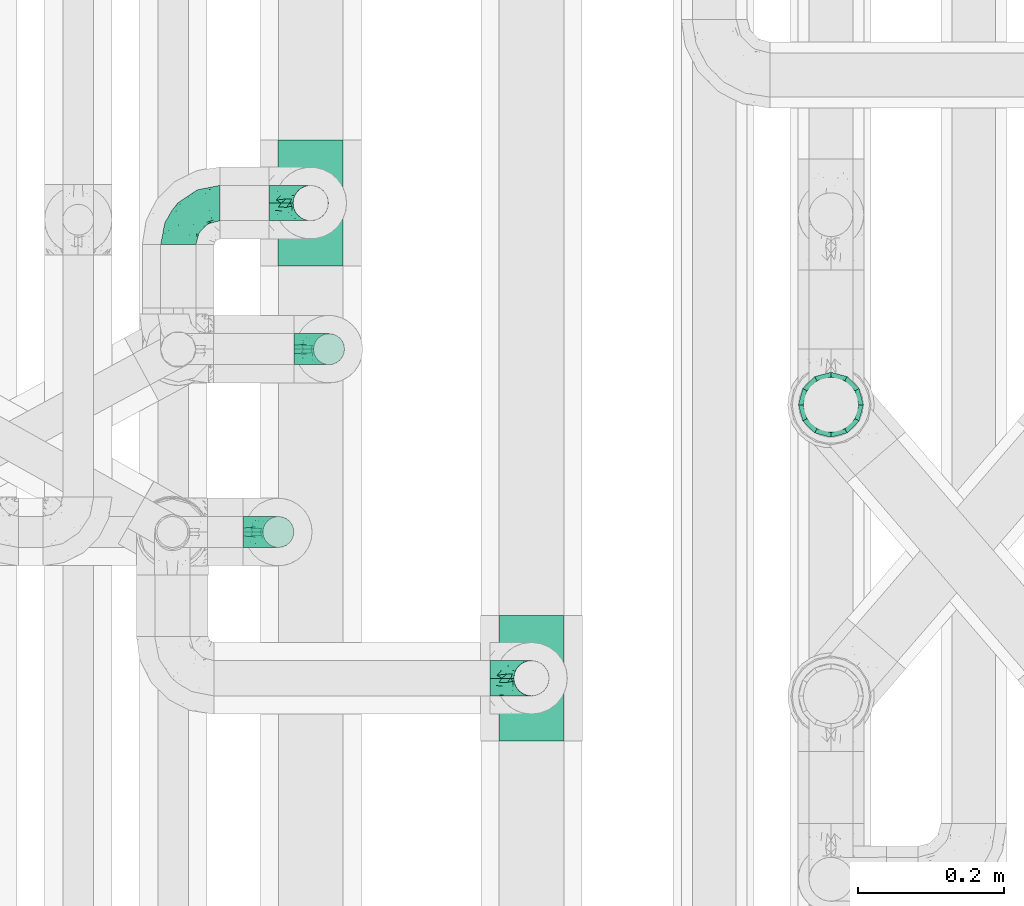
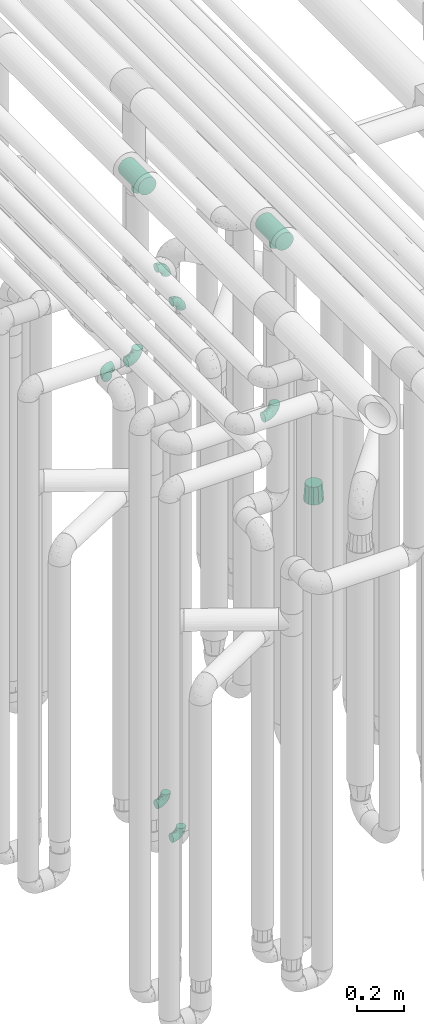
# One storey, part 615 of 824: 10 flow fittings.
"""IFC2X3 building model written with IfcOpenShell, lengths in millimetres."""

import ifcopenshell
import ifcopenshell.guid

model = None  # the IFC model being written
_history = None  # IfcOwnerHistory: only IFC2X3 demands one
_inside = {}  # id of a spatial element -> (the spatial element, [elements in it])
_under = {}  # id of a project, library or spatial element -> (it, [spatial elements below it])
_declared = {}  # id of a project -> (the project, [libraries it declares])
_typed = {}  # id of a type object -> (the type object, [elements of that type])
_made_of = {}  # id of a material, layer set ... -> (it, [elements and type objects made of it])


def new_model(schema):
    """Start an empty IFC model of exactly this schema.

    Asked for "IFC4X3", IfcOpenShell would pick the latest addendum, in which some entities
    have other attributes; the version numbers below select the first issue.
    IFC2X3 requires an IfcOwnerHistory on every rooted entity: one is made here for all.
    """
    global model, _history
    if schema == "IFC4X3":
        model = ifcopenshell.file(schema_version=(4, 3, 0, 0))
    else:
        model = ifcopenshell.file(schema=schema)
    _inside.clear()
    _under.clear()
    _declared.clear()
    _typed.clear()
    _made_of.clear()
    _history = None
    if model.schema == "IFC2X3":
        org = make("IfcOrganization", Name="unknown")
        user = make(
            "IfcPersonAndOrganization",
            ThePerson=make("IfcPerson", FamilyName="unknown"),
            TheOrganization=org,
        )
        app = make(
            "IfcApplication",
            ApplicationDeveloper=org,
            Version="unknown",
            ApplicationFullName="unknown",
            ApplicationIdentifier="unknown",
        )
        _history = make(
            "IfcOwnerHistory",
            OwningUser=user,
            OwningApplication=app,
            ChangeAction="ADDED",
            CreationDate=0,
        )
    return model


def make(cls, **values):
    """One entity of the class cls with the attributes given. An attribute that is None is left unset."""
    return model.create_entity(
        cls, **{name: value for name, value in values.items() if value is not None}
    )


def entity(cls, *values):
    """Any entity or typed value of the class cls, its attributes in the order of the schema. None: left unset."""
    e = model.create_entity(cls)
    for i, value in enumerate(values):
        if value is not None:
            e[i] = value
    return e


def rooted(cls, **values):
    """An entity with a GlobalId (a new one), such as an element, a storey or a relation."""
    return make(cls, GlobalId=ifcopenshell.guid.new(), OwnerHistory=_history, **values)


def si_unit(unit_type, name, prefix=None):
    """IfcSIUnit, for example si_unit("LENGTHUNIT", "METRE", prefix="MILLI")."""
    return make("IfcSIUnit", UnitType=unit_type, Prefix=prefix, Name=name)


def converted_unit(unit_type, name, factor, base, dimensions=None, offset=None):
    """IfcConversionBasedUnit, such as the inch: factor (a typed value) times the base unit."""
    return make(
        "IfcConversionBasedUnit"
        if offset is None
        else "IfcConversionBasedUnitWithOffset",
        ConversionOffset=offset,
        Dimensions=None
        if dimensions is None
        else entity("IfcDimensionalExponents", *dimensions),
        UnitType=unit_type,
        Name=name,
        ConversionFactor=make(
            "IfcMeasureWithUnit", ValueComponent=factor, UnitComponent=base
        ),
    )


def derived_unit(unit_type, elements):
    """IfcDerivedUnit: a product of units, each with its exponent."""
    return make(
        "IfcDerivedUnit",
        Elements=[
            make("IfcDerivedUnitElement", Unit=unit, Exponent=power)
            for unit, power in elements
        ],
        UnitType=unit_type,
    )


def assignment(units):
    """IfcUnitAssignment: the units of a project."""
    return None if units is None else make("IfcUnitAssignment", Units=units)


def point(xyz):
    """IfcCartesianPoint."""
    return None if xyz is None else make("IfcCartesianPoint", Coordinates=xyz)


def direction(xyz):
    """IfcDirection."""
    return None if xyz is None else make("IfcDirection", DirectionRatios=xyz)


def frame(location, z_axis=None, x_axis=None):
    """IfcAxis2Placement3D, a coordinate frame: its origin and axes. An axis left out is left unset."""
    return make(
        "IfcAxis2Placement3D",
        Location=point(location),
        Axis=direction(z_axis),
        RefDirection=direction(x_axis),
    )


def origin():
    """The frame at (0, 0, 0) with its axes left unset."""
    return frame((0.0, 0.0, 0.0))


def place(relative_to, where):
    """IfcLocalPlacement: puts the frame where relative to a parent placement (None: the world)."""
    return make(
        "IfcLocalPlacement", PlacementRelTo=relative_to, RelativePlacement=where
    )


def context(
    kind, dimensions, precision=None, world=None, true_north=None, identifier=None
):
    """IfcGeometricRepresentationContext, for example the 3D "Model" context."""
    return make(
        "IfcGeometricRepresentationContext",
        ContextIdentifier=identifier,
        ContextType=kind,
        CoordinateSpaceDimension=dimensions,
        Precision=precision,
        WorldCoordinateSystem=world,
        TrueNorth=true_north,
    )


def subcontext(parent, identifier, kind, view, scale=None):
    """IfcGeometricRepresentationSubContext, for example "Body" below "Model"."""
    return make(
        "IfcGeometricRepresentationSubContext",
        ContextIdentifier=identifier,
        ContextType=kind,
        ParentContext=parent,
        TargetScale=scale,
        TargetView=view,
    )


def project(units=None, contexts=None):
    """IfcProject with its units and contexts."""
    return rooted(
        "IfcProject",
        Name="project",
        RepresentationContexts=contexts,
        UnitsInContext=assignment(units),
    )


def spatial(cls, under=None, at=None, **own):
    """A site, building, storey or space (cls), placed at a placement, below another one or the project."""
    s = rooted(cls, ObjectPlacement=at, **own)
    if under is not None:
        _under.setdefault(under.id(), (under, []))[1].append(s)
    return s


def faces_of(points, faces, orient=None, outer=None):
    """IfcFace entities. A face is a list of loops; a loop is a list of indices into points, from 0.

    orient and outer hold one flag for each loop. By default every Orientation is true, the
    first loop of a face is its IfcFaceOuterBound and the others are IfcFaceBound.
    """
    made = []
    for i, loops in enumerate(faces):
        bounds = []
        for j, loop in enumerate(loops):
            is_outer = j == 0 if outer is None else outer[i][j]
            bounds.append(
                make(
                    "IfcFaceOuterBound" if is_outer else "IfcFaceBound",
                    Bound=make("IfcPolyLoop", Polygon=[points[k] for k in loop]),
                    Orientation=True if orient is None else orient[i][j],
                )
            )
        made.append(make("IfcFace", Bounds=bounds))
    return made


def faceted_brep(points, faces, orient=None, outer=None, voids=None):
    """IfcFacetedBrep: a solid bounded by flat faces; with voids (closed shells), ...WithVoids."""
    shared = [point(p) for p in points]
    hull = make("IfcClosedShell", CfsFaces=faces_of(shared, faces, orient, outer))
    if voids is None:
        return make("IfcFacetedBrep", Outer=hull)
    return make(
        "IfcFacetedBrepWithVoids",
        Outer=hull,
        Voids=[
            make(cls, CfsFaces=faces_of(shared, fs, o, b)) for cls, fs, o, b in voids
        ],
    )


def shape(context_of_items, identifier, shape_type, items):
    """IfcShapeRepresentation: the items that make up one representation, for example the "Body"."""
    return make(
        "IfcShapeRepresentation",
        ContextOfItems=context_of_items,
        RepresentationIdentifier=identifier,
        RepresentationType=shape_type,
        Items=items,
    )


def source(mapping_origin, context_of_items, identifier, shape_type, items):
    """IfcRepresentationMap: a shape defined once, which mapped items show again and again."""
    return make(
        "IfcRepresentationMap",
        MappingOrigin=mapping_origin,
        MappedRepresentation=shape(context_of_items, identifier, shape_type, items),
    )


def transform(
    local_origin,
    x_axis=None,
    y_axis=None,
    z_axis=None,
    scale=None,
    scale2=None,
    scale3=None,
    uniform=True,
):
    """IfcCartesianTransformationOperator3D, or its non-uniform kind. x_axis, y_axis, z_axis: its Axis1, 2, 3."""
    if uniform:
        return make(
            "IfcCartesianTransformationOperator3D",
            Axis1=direction(x_axis),
            Axis2=direction(y_axis),
            LocalOrigin=point(local_origin),
            Scale=scale,
            Axis3=direction(z_axis),
        )
    return make(
        "IfcCartesianTransformationOperator3DnonUniform",
        Axis1=direction(x_axis),
        Axis2=direction(y_axis),
        LocalOrigin=point(local_origin),
        Scale=scale,
        Axis3=direction(z_axis),
        Scale2=scale2,
        Scale3=scale3,
    )


def mapped(mapping_source, mapping_target):
    """IfcMappedItem: shows the shape of a source again, moved by a transform."""
    return make(
        "IfcMappedItem", MappingSource=mapping_source, MappingTarget=mapping_target
    )


def material(Name=None, Category=None):
    """IfcMaterial."""
    return make("IfcMaterial", Name=Name, Category=Category)


def made_of(thing, what):
    """Note that an element or type object is made of a material, layer set ...; save() writes the relation."""
    if what is not None:
        _made_of.setdefault(what.id(), (what, []))[1].append(thing)
    return thing


def type_object(cls, material=None, **own):
    """A type object (cls), such as IfcWallType, which elements share."""
    return made_of(rooted(cls, **own), material)


def type_shapes(of_type, sources):
    """Give a type object the sources (RepresentationMaps) that its elements show as mapped items."""
    of_type.RepresentationMaps = sources


def element(
    cls,
    number,
    at=None,
    inside=None,
    cuts=None,
    type_object=None,
    material=None,
    context=None,
    identifier="Body",
    shape_type=None,
    held_by="IfcProductDefinitionShape",
    body=None,
    shapes=None,
    **own,
):
    """One element of the class cls, such as IfcWall. Its Tag is "e" and its number.

    at: its placement. inside: the storey or other place that contains it. cuts: it is an
    opening in that element (IfcRelVoidsElement). A single representation is given by context,
    identifier, shape_type and body (its items); several are given by shapes. held_by: the class
    of the entity that holds the representations. save() writes the other relations.
    """
    e = rooted(cls, Tag="e%d" % number, ObjectPlacement=at, **own)
    if body is not None:
        shapes = [shape(context, identifier, shape_type, body)]
    if shapes is not None:
        e.Representation = make(held_by, Representations=shapes)
    if inside is not None:
        _inside.setdefault(inside.id(), (inside, []))[1].append(e)
    if cuts is not None:
        rooted(
            "IfcRelVoidsElement", RelatingBuildingElement=cuts, RelatedOpeningElement=e
        )
    if type_object is not None:
        _typed.setdefault(type_object.id(), (type_object, []))[1].append(e)
    return made_of(e, material)


def aggregate(whole, parts):
    """IfcRelAggregates: a whole, such as a stair, and the parts it consists of."""
    return rooted("IfcRelAggregates", RelatingObject=whole, RelatedObjects=parts)


def save(model, path):
    """Write the relations noted so far, then the file.

    IfcRelAggregates (storeys below a building ...), IfcRelContainedInSpatialStructure (elements
    in a storey), IfcRelDefinesByType, IfcRelAssociatesMaterial and IfcRelDeclares: one each for
    every whole, place, type object, material and project.
    """
    for whole, parts in _under.values():
        aggregate(whole, parts)
    for where, things in _inside.values():
        rooted(
            "IfcRelContainedInSpatialStructure",
            RelatedElements=things,
            RelatingStructure=where,
        )
    for kind, things in _typed.values():
        rooted("IfcRelDefinesByType", RelatedObjects=things, RelatingType=kind)
    for what, things in _made_of.values():
        rooted("IfcRelAssociatesMaterial", RelatedObjects=things, RelatingMaterial=what)
    for by, libraries in _declared.values():
        rooted("IfcRelDeclares", RelatingContext=by, RelatedDefinitions=libraries)
    model.write(path)


model = new_model("IFC2X3")

# Units and contexts
model_context = context("Model", 3, precision=0.01, world=origin(), true_north=direction((6.12303176911189e-17, 1.0)))
body_context = subcontext(model_context, "Body", "Model", "MODEL_VIEW")
ifc_project = project(units=[si_unit("LENGTHUNIT", "METRE", prefix="MILLI"), si_unit("AREAUNIT", "SQUARE_METRE"), si_unit("VOLUMEUNIT", "CUBIC_METRE"), converted_unit("PLANEANGLEUNIT", "DEGREE", entity("IfcRatioMeasure", 0.0174532925199433), si_unit("PLANEANGLEUNIT", "RADIAN"), dimensions=[0, 0, 0, 0, 0, 0, 0]), si_unit("MASSUNIT", "GRAM", prefix="KILO"), derived_unit("MASSDENSITYUNIT", [(si_unit("MASSUNIT", "GRAM", prefix="KILO"), 1), (si_unit("LENGTHUNIT", "METRE"), -3)]), derived_unit("MOMENTOFINERTIAUNIT", [(si_unit("LENGTHUNIT", "METRE"), 4)]), si_unit("TIMEUNIT", "SECOND"), si_unit("FREQUENCYUNIT", "HERTZ"), si_unit("THERMODYNAMICTEMPERATUREUNIT", "DEGREE_CELSIUS"), derived_unit("THERMALTRANSMITTANCEUNIT", [(si_unit("MASSUNIT", "GRAM", prefix="KILO"), 1), (si_unit("THERMODYNAMICTEMPERATUREUNIT", "KELVIN"), -1), (si_unit("TIMEUNIT", "SECOND"), -3)]), derived_unit("VOLUMETRICFLOWRATEUNIT", [(si_unit("LENGTHUNIT", "METRE"), 3), (si_unit("TIMEUNIT", "SECOND"), -1)]), derived_unit("MASSFLOWRATEUNIT", [(si_unit("MASSUNIT", "GRAM", prefix="KILO"), 1), (si_unit("TIMEUNIT", "SECOND"), -1)]), derived_unit("ROTATIONALFREQUENCYUNIT", [(si_unit("TIMEUNIT", "SECOND"), -1)]), si_unit("ELECTRICCURRENTUNIT", "AMPERE"), si_unit("ELECTRICVOLTAGEUNIT", "VOLT"), si_unit("POWERUNIT", "WATT"), si_unit("FORCEUNIT", "NEWTON", prefix="KILO"), si_unit("ILLUMINANCEUNIT", "LUX"), si_unit("LUMINOUSFLUXUNIT", "LUMEN"), si_unit("LUMINOUSINTENSITYUNIT", "CANDELA"), derived_unit("USERDEFINED", [(si_unit("MASSUNIT", "GRAM", prefix="KILO"), -1), (si_unit("LENGTHUNIT", "METRE"), -2), (si_unit("TIMEUNIT", "SECOND"), 3), (si_unit("LUMINOUSFLUXUNIT", "LUMEN"), 1)]), derived_unit("LINEARVELOCITYUNIT", [(si_unit("LENGTHUNIT", "METRE"), 1), (si_unit("TIMEUNIT", "SECOND"), -1)]), si_unit("PRESSUREUNIT", "PASCAL"), derived_unit("USERDEFINED", [(si_unit("LENGTHUNIT", "METRE"), -2), (si_unit("MASSUNIT", "GRAM", prefix="KILO"), 1), (si_unit("TIMEUNIT", "SECOND"), -2)]), derived_unit("LINEARFORCEUNIT", [(si_unit("MASSUNIT", "GRAM", prefix="KILO"), 1), (si_unit("LENGTHUNIT", "METRE"), 1), (si_unit("TIMEUNIT", "SECOND"), -2), (si_unit("LENGTHUNIT", "METRE"), -1)]), derived_unit("PLANARFORCEUNIT", [(si_unit("MASSUNIT", "GRAM", prefix="KILO"), 1), (si_unit("LENGTHUNIT", "METRE"), 1), (si_unit("TIMEUNIT", "SECOND"), -2), (si_unit("LENGTHUNIT", "METRE"), -2)])], contexts=[model_context])

# Site, building, storey
site_placement = place(None, origin())
site = spatial("IfcSite", under=ifc_project, at=site_placement, CompositionType="ELEMENT")
building_placement = place(site_placement, origin())
building = spatial("IfcBuilding", under=site, at=building_placement, CompositionType="ELEMENT")
storey_placement = place(building_placement, frame((0.0, 0.0, 28200.0)))
storey = spatial("IfcBuildingStorey", under=building, at=storey_placement, CompositionType="ELEMENT", Elevation=28200.0)

# Flow fittings
ifc_material = material()
pipe_fitting_type_1 = type_object("IfcPipeFittingType", PredefinedType="NOTDEFINED", material=ifc_material)
shared_shape_1 = source(origin(), body_context, "Body", "Brep", [
    faceted_brep([(-57.0, 12.07, -20.91), (-57.0, 6.25, -23.33), (-57.0, 0.0, -24.15), (-57.0, -6.25, -23.33), (-57.0, -12.08, -20.91), (-57.0, -17.08, -17.08), (-57.0, -20.91, -12.08), (-57.0, -23.33, -6.25), (-57.0, -24.15, 0.0), (-57.0, -23.33, 6.25), (-57.0, -20.91, 12.07), (-57.0, -17.08, 17.08), (-57.0, -12.08, 20.91), (-57.0, -6.25, 23.33), (-57.0, 0.0, 24.15), (-57.0, 6.25, 23.33), (-57.0, 12.07, 20.91), (-57.0, 17.08, 17.08), (-57.0, 20.91, 12.07), (-57.0, 23.33, 6.25), (-57.0, 24.15, 0.0), (-57.0, 23.33, -6.25), (-57.0, 20.91, -12.08), (-57.0, 17.08, -17.08), (0.0, 57.0, -24.15), (-6.25, 57.0, -23.33), (-12.07, 57.0, -20.91), (-17.08, 57.0, -17.08), (-20.91, 57.0, -12.08), (-23.33, 57.0, -6.25), (-24.15, 57.0, 0.0), (-23.33, 57.0, 6.25), (-20.91, 57.0, 12.07), (-17.08, 57.0, 17.08), (-12.07, 57.0, 20.91), (-6.25, 57.0, 23.33), (0.0, 57.0, 24.15), (6.25, 57.0, 23.33), (12.08, 57.0, 20.91), (17.08, 57.0, 17.08), (20.91, 57.0, 12.07), (23.33, 57.0, 6.25), (24.15, 57.0, 0.0), (23.33, 57.0, -6.25), (20.91, 57.0, -12.08), (17.08, 57.0, -17.08), (12.08, 57.0, -20.91), (6.25, 57.0, -23.33), (14.9, 21.14, 6.17), (13.61, 24.64, 12.48), (6.23, 8.95, 8.98), (-41.47, -21.06, 0.0), (-41.92, -18.38, 13.72), (-24.64, -13.61, 12.48), (-37.37, -13.24, 18.15), (-6.8, -4.93, 8.18), (-21.76, -15.19, 6.22), (-12.78, -9.18, 0.0), (-37.73, -20.51, 7.75), (-7.38, 7.38, 20.24), (-23.37, -4.26, 20.42), (-11.9, -3.19, 15.86), (-42.14, -8.7, 21.82), (13.24, 37.37, 18.15), (9.33, 23.53, 16.85), (4.26, 23.37, 20.42), (2.77, 10.92, 15.55), (-29.46, 0.91, 23.52), (-44.13, 20.56, 15.69), (-39.25, 26.33, 10.88), (-49.02, 22.92, 9.96), (-34.58, 23.87, 17.15), (-15.8, 6.8, 22.81), (-8.67, 20.47, 23.88), (-18.12, 12.9, 24.08), (-48.29, 14.92, 19.65), (-44.06, -2.85, 23.78), (-9.23, 48.95, 22.58), (-3.78, 42.74, 24.07), (-40.34, 4.26, 24.09), (-44.02, 26.14, 5.46), (-44.04, 9.88, 22.74), (-4.95, 16.87, 22.52), (-2.75, 1.43, 12.5), (-25.48, 40.98, 10.71), (20.51, 37.73, 7.75), (18.38, 41.92, 13.72), (8.7, 42.14, 21.82), (-25.95, -17.97, 0.0), (2.85, 44.06, 23.78), (21.06, 41.47, 0.0), (17.97, 25.95, 0.0), (-24.04, -9.27, 17.13), (-33.26, 33.26, 5.86), (-28.55, 40.57, 0.0), (-40.57, 28.55, 0.0), (-25.29, 47.19, 4.06), (-27.01, 31.1, 16.77), (-15.7, 43.95, 19.9), (-20.27, 45.22, 15.61), (-30.53, 31.98, 12.64), (-11.28, 38.33, 22.92), (-9.97, 27.88, 24.09), (-20.15, 30.26, 21.25), (-31.25, 11.75, 23.64), (-28.75, 7.23, 24.15), (-29.53, 18.06, 22.27), (-28.44, 24.21, 20.02), (-37.55, 17.7, 20.26), (-15.88, 29.25, 22.99), (-20.82, 20.82, 23.44), (-0.91, 29.46, 23.52), (-13.5, -7.67, 12.04), (1.49, 1.56, 5.16), (8.86, 10.35, 4.59), (0.38, -0.38, 0.0), (9.18, 12.78, 0.0), (-37.37, -13.24, -18.15), (8.86, 10.35, -4.59), (-45.22, 20.27, -15.61), (-43.95, 15.7, -19.9), (-38.33, 11.28, -22.92), (-48.95, 9.23, -22.58), (-47.19, 25.29, -4.06), (-33.26, 33.26, -5.86), (18.38, 41.92, -13.72), (-30.26, 20.15, -21.25), (2.85, 44.06, -23.78), (-4.26, 40.34, -24.09), (-40.98, 25.48, -10.71), (-41.92, -18.38, -13.72), (9.25, 23.5, -16.92), (4.26, 23.37, -20.42), (13.24, 37.37, -18.15), (-37.73, -20.51, -7.75), (-11.75, 31.25, -23.64), (-7.23, 28.75, -24.15), (-12.9, 18.12, -24.08), (8.7, 42.14, -21.82), (-44.06, -2.85, -23.78), (-6.8, 15.8, -22.81), (-20.47, 8.67, -23.88), (-24.64, -13.61, -12.48), (-42.74, 3.78, -24.07), (-18.06, 29.53, -22.27), (-24.21, 28.44, -20.02), (-27.88, 9.97, -24.09), (-31.1, 27.01, -16.77), (-26.14, 44.02, -5.46), (14.9, 21.14, -6.17), (20.51, 37.73, -7.75), (-9.88, 44.04, -22.74), (-20.56, 44.13, -15.69), (-21.76, -15.19, -6.22), (-13.5, -7.67, -12.04), (-24.14, -9.76, -16.74), (-11.9, -3.19, -15.86), (-14.92, 48.29, -19.65), (-23.37, -4.26, -20.42), (-0.91, 29.46, -23.52), (-26.33, 39.25, -10.88), (-23.87, 34.58, -17.15), (-42.14, -8.7, -21.82), (-22.92, 49.02, -9.96), (13.61, 24.64, -12.48), (-31.98, 30.53, -12.64), (-16.87, 4.95, -22.52), (-17.7, 37.55, -20.26), (-29.25, 15.88, -22.99), (-20.82, 20.82, -23.44), (-29.46, 0.91, -23.52), (-7.38, 7.38, -20.24), (2.77, 10.92, -15.55), (6.23, 8.95, -8.98), (-6.8, -4.93, -8.18), (-2.81, 1.41, -12.54), (1.49, 1.56, -5.16)], [[[0, 1, 2, 3, 4, 5, 6, 7, 8, 9, 10, 11, 12, 13, 14, 15, 16, 17, 18, 19, 20, 21, 22, 23]], [[24, 25, 26, 27, 28, 29, 30, 31, 32, 33, 34, 35, 36, 37, 38, 39, 40, 41, 42, 43, 44, 45, 46, 47]], [[48, 49, 50]], [[9, 8, 51]], [[52, 53, 54]], [[55, 56, 57]], [[10, 58, 52]], [[9, 58, 10]], [[59, 60, 61]], [[54, 12, 11]], [[54, 62, 12]], [[63, 39, 38]], [[64, 65, 66]], [[62, 60, 67]], [[68, 69, 70]], [[71, 69, 68]], [[72, 73, 74]], [[16, 75, 17]], [[13, 76, 14]], [[35, 77, 78]], [[14, 79, 15]], [[17, 68, 18]], [[14, 76, 79]], [[20, 19, 80]], [[70, 19, 18]], [[81, 15, 79]], [[15, 81, 16]], [[73, 72, 82]], [[66, 83, 50]], [[32, 31, 84]], [[85, 86, 49]], [[63, 87, 65]], [[56, 58, 88]], [[36, 89, 37]], [[85, 41, 40]], [[36, 35, 78]], [[90, 41, 85]], [[40, 39, 86]], [[12, 62, 13]], [[86, 85, 40]], [[48, 85, 49]], [[85, 91, 90]], [[87, 38, 37]], [[92, 60, 54]], [[80, 69, 93]], [[93, 94, 95]], [[10, 52, 11]], [[94, 96, 30]], [[97, 98, 99]], [[80, 93, 95]], [[100, 97, 84]], [[99, 98, 33]], [[101, 102, 78]], [[103, 101, 98]], [[96, 31, 30]], [[77, 98, 101]], [[77, 35, 34]], [[34, 33, 98]], [[9, 51, 58]], [[87, 63, 38]], [[104, 105, 74]], [[106, 103, 107]], [[106, 81, 104]], [[75, 68, 17]], [[108, 107, 71]], [[33, 32, 99]], [[109, 103, 110]], [[101, 109, 102]], [[89, 78, 111]], [[53, 52, 58]], [[54, 11, 52]], [[60, 62, 54]], [[88, 58, 51]], [[76, 62, 67]], [[53, 112, 92]], [[60, 59, 72]], [[39, 63, 86]], [[49, 86, 63]], [[89, 87, 37]], [[42, 41, 90]], [[111, 82, 65]], [[111, 65, 87]], [[65, 59, 66]], [[104, 81, 79]], [[75, 81, 108]], [[32, 84, 99]], [[97, 99, 84]], [[98, 97, 103]], [[106, 107, 108]], [[74, 102, 110]], [[111, 78, 102]], [[74, 110, 104]], [[74, 67, 72]], [[61, 92, 112]], [[66, 59, 61]], [[56, 53, 58]], [[66, 50, 49]], [[61, 112, 83]], [[66, 49, 64]], [[78, 89, 36]], [[87, 89, 111]], [[62, 76, 13]], [[79, 76, 67]], [[100, 93, 69]], [[96, 93, 84]], [[55, 113, 50]], [[113, 114, 50]], [[104, 79, 105]], [[106, 104, 110]], [[20, 80, 95]], [[85, 48, 91]], [[115, 114, 113]], [[116, 91, 48]], [[70, 80, 19]], [[93, 96, 94]], [[84, 31, 96]], [[103, 106, 110]], [[81, 106, 108]], [[103, 97, 107]], [[71, 107, 97]], [[71, 97, 100]], [[108, 71, 68]], [[79, 67, 105]], [[67, 74, 105]], [[115, 113, 57]], [[112, 56, 55]], [[56, 88, 57]], [[60, 72, 67]], [[82, 72, 59]], [[65, 82, 59]], [[82, 111, 73]], [[111, 102, 73]], [[102, 74, 73]], [[81, 75, 16]], [[68, 75, 108]], [[68, 70, 18]], [[80, 70, 69]], [[98, 77, 34]], [[78, 77, 101]], [[93, 100, 84]], [[71, 100, 69]], [[102, 109, 110]], [[101, 103, 109]], [[53, 92, 54]], [[61, 60, 92]], [[56, 112, 53]], [[83, 112, 55]], [[50, 83, 55]], [[61, 83, 66]], [[49, 63, 64]], [[65, 64, 63]], [[57, 113, 55]], [[114, 115, 116]], [[116, 48, 114]], [[48, 50, 114]], [[117, 5, 4]], [[116, 115, 118]], [[119, 120, 23]], [[121, 122, 120]], [[95, 123, 20]], [[0, 23, 120]], [[124, 95, 94]], [[125, 45, 44]], [[121, 120, 126]], [[24, 127, 128]], [[22, 21, 129]], [[0, 122, 1]], [[5, 117, 130]], [[131, 132, 133]], [[134, 88, 51]], [[135, 136, 137]], [[6, 5, 130]], [[46, 138, 47]], [[139, 3, 2]], [[140, 141, 137]], [[6, 134, 7]], [[134, 130, 142]], [[143, 2, 1]], [[144, 126, 145]], [[121, 146, 143]], [[147, 120, 119]], [[94, 148, 124]], [[149, 150, 91]], [[30, 29, 148]], [[151, 25, 128]], [[27, 152, 28]], [[134, 153, 88]], [[154, 155, 156]], [[27, 26, 157]], [[151, 26, 25]], [[155, 158, 156]], [[24, 47, 127]], [[1, 122, 143]], [[138, 132, 159]], [[160, 152, 161]], [[24, 128, 25]], [[46, 133, 138]], [[162, 117, 4]], [[148, 160, 124]], [[152, 160, 163]], [[154, 142, 155]], [[45, 125, 133]], [[133, 46, 45]], [[125, 164, 133]], [[51, 7, 134]], [[42, 90, 43]], [[165, 147, 129]], [[153, 134, 142]], [[43, 150, 44]], [[162, 4, 3]], [[141, 140, 166]], [[117, 162, 158]], [[163, 29, 28]], [[43, 90, 150]], [[123, 21, 20]], [[144, 151, 135]], [[157, 152, 27]], [[167, 145, 161]], [[23, 22, 119]], [[168, 126, 169]], [[121, 168, 146]], [[139, 143, 170]], [[142, 130, 117]], [[8, 7, 51]], [[134, 6, 130]], [[139, 162, 3]], [[170, 166, 158]], [[170, 158, 162]], [[158, 171, 156]], [[44, 150, 125]], [[91, 150, 90]], [[164, 125, 150]], [[132, 138, 133]], [[127, 138, 159]], [[131, 164, 172]], [[132, 171, 140]], [[135, 151, 128]], [[157, 151, 167]], [[22, 129, 119]], [[147, 119, 129]], [[120, 147, 126]], [[144, 145, 167]], [[137, 146, 169]], [[170, 143, 146]], [[137, 169, 135]], [[137, 159, 140]], [[171, 172, 156]], [[173, 174, 175]], [[156, 175, 154]], [[174, 57, 153]], [[132, 172, 171]], [[172, 164, 173]], [[143, 139, 2]], [[162, 139, 170]], [[138, 127, 47]], [[128, 127, 159]], [[165, 124, 160]], [[123, 124, 129]], [[149, 173, 164]], [[176, 174, 173]], [[135, 128, 136]], [[144, 135, 169]], [[150, 149, 164]], [[176, 118, 115]], [[149, 91, 116]], [[30, 148, 94]], [[163, 148, 29]], [[124, 123, 95]], [[129, 21, 123]], [[126, 144, 169]], [[151, 144, 167]], [[126, 147, 145]], [[161, 145, 147]], [[161, 147, 165]], [[167, 161, 152]], [[128, 159, 136]], [[159, 137, 136]], [[154, 153, 142]], [[132, 140, 159]], [[174, 176, 57]], [[57, 88, 153]], [[166, 140, 171]], [[158, 166, 171]], [[166, 170, 141]], [[170, 146, 141]], [[146, 137, 141]], [[151, 157, 26]], [[152, 157, 167]], [[152, 163, 28]], [[148, 163, 160]], [[120, 122, 0]], [[143, 122, 121]], [[124, 165, 129]], [[161, 165, 160]], [[146, 168, 169]], [[121, 126, 168]], [[142, 117, 155]], [[158, 155, 117]], [[175, 156, 172]], [[153, 154, 174]], [[173, 175, 172]], [[174, 154, 175]], [[164, 131, 133]], [[172, 132, 131]], [[176, 173, 118]], [[57, 176, 115]], [[173, 149, 118]], [[149, 116, 118]]]),
])
type_shapes(pipe_fitting_type_1, [shared_shape_1])
for number, where, z_axis, x_axis in (
    (1, (35736.85, 12006.08, 2600.0), (0.0, 0.0, 1.0), (-1.0, 0.0, 0.0)),
    (2, (36220.03, 11356.08, 2600.0), (0.0, -1.0, 0.0), (1.0, 0.0, 0.0)),
    (3, (35918.07, 12006.08, 2600.0), (0.0, -1.0, 0.0), (1.0, 0.0, 0.0)),
):
    element("IfcFlowFitting", number, at=place(storey_placement, frame(where, z_axis=z_axis, x_axis=x_axis)), inside=storey, type_object=pipe_fitting_type_1, material=ifc_material, context=body_context, shape_type="MappedRepresentation", body=[
        mapped(shared_shape_1, transform((0.0, 0.0, 0.0), scale=1.0)),
    ])
pipe_fitting_type_2 = type_object("IfcPipeFittingType", PredefinedType="NOTDEFINED", material=ifc_material)
shared_shape_2 = source(origin(), body_context, "Body", "Brep", [
    faceted_brep([(-48.0, 10.6, -18.36), (-48.0, 5.49, -20.48), (-48.0, 0.0, -21.2), (-48.0, -5.49, -20.48), (-48.0, -10.6, -18.36), (-48.0, -14.99, -14.99), (-48.0, -18.36, -10.6), (-48.0, -20.48, -5.49), (-48.0, -21.2, 0.0), (-48.0, -20.48, 5.49), (-48.0, -18.36, 10.6), (-48.0, -14.99, 14.99), (-48.0, -10.6, 18.36), (-48.0, -5.49, 20.48), (-48.0, 0.0, 21.2), (-48.0, 5.49, 20.48), (-48.0, 10.6, 18.36), (-48.0, 14.99, 14.99), (-48.0, 18.36, 10.6), (-48.0, 20.48, 5.49), (-48.0, 21.2, 0.0), (-48.0, 20.48, -5.49), (-48.0, 18.36, -10.6), (-48.0, 14.99, -14.99), (0.0, 48.0, -21.2), (-5.49, 48.0, -20.48), (-10.6, 48.0, -18.36), (-14.99, 48.0, -14.99), (-18.36, 48.0, -10.6), (-20.48, 48.0, -5.49), (-21.2, 48.0, 0.0), (-20.48, 48.0, 5.49), (-18.36, 48.0, 10.6), (-14.99, 48.0, 14.99), (-10.6, 48.0, 18.36), (-5.49, 48.0, 20.48), (0.0, 48.0, 21.2), (5.49, 48.0, 20.48), (10.6, 48.0, 18.36), (14.99, 48.0, 14.99), (18.36, 48.0, 10.6), (20.48, 48.0, 5.49), (21.2, 48.0, 0.0), (20.48, 48.0, -5.49), (18.36, 48.0, -10.6), (14.99, 48.0, -14.99), (10.6, 48.0, -18.36), (5.49, 48.0, -20.48), (-35.25, -16.22, 12.01), (-34.76, -18.57, 0.0), (-20.87, -12.37, 10.9), (-31.49, -11.78, 15.9), (-37.0, -2.58, 20.86), (-33.89, 3.62, 21.15), (-31.81, -18.14, 6.76), (-5.78, 5.78, 17.67), (-19.42, -4.1, 17.86), (-9.6, -3.39, 13.73), (-35.44, -7.73, 19.13), (11.78, 31.49, 15.9), (-5.93, -5.46, 6.95), (-18.45, -13.78, 5.46), (-10.29, -8.43, 0.0), (-24.6, 0.55, 20.62), (-37.28, 17.94, 13.81), (-33.38, 22.85, 9.59), (-41.46, 20.06, 8.75), (-29.51, 20.45, 15.16), (-15.04, 10.79, 21.13), (-7.08, 16.98, 20.93), (-8.39, 23.51, 21.15), (-40.86, 13.03, 17.26), (-8.05, 41.26, 19.83), (-3.21, 35.97, 21.14), (8.53, 19.66, 14.74), (4.1, 19.42, 17.86), (-37.72, 22.66, 4.78), (-37.07, 8.58, 19.98), (-13.0, 5.43, 19.97), (-3.78, 13.93, 19.7), (3.02, 8.69, 13.43), (-2.27, -0.05, 10.65), (6.22, 6.99, 7.09), (-22.25, 34.6, 9.45), (18.14, 31.81, 6.76), (16.22, 35.25, 12.01), (12.37, 20.87, 10.9), (7.73, 35.44, 19.13), (-21.52, -15.93, 0.0), (2.58, 37.0, 20.86), (18.57, 34.76, 0.0), (13.78, 18.45, 5.46), (15.93, 21.52, 0.0), (-20.03, -8.54, 14.9), (-28.6, 28.6, 5.16), (-24.79, 34.6, 0.0), (-34.6, 24.79, 0.0), (-22.81, 37.41, 4.68), (-23.36, 26.33, 14.79), (-13.68, 37.05, 17.49), (-17.72, 38.12, 13.73), (-26.25, 27.3, 11.24), (-9.71, 32.34, 20.14), (-17.26, 25.6, 18.71), (-26.33, 9.99, 20.77), (-24.06, 6.05, 21.2), (-25.02, 15.46, 19.56), (-24.3, 20.72, 17.57), (-31.95, 15.23, 17.8), (-13.53, 24.7, 20.21), (-17.6, 17.6, 20.6), (-0.55, 24.6, 20.62), (-11.41, -7.48, 10.43), (0.93, -0.93, 0.0), (8.43, 10.29, 0.0), (-11.41, -7.48, -10.43), (-20.1, -8.84, -14.66), (-9.6, -3.39, -13.73), (7.73, 35.44, -19.13), (4.1, 19.42, -17.86), (-0.55, 24.6, -20.62), (-38.12, 17.72, -13.73), (-37.05, 13.68, -17.49), (-32.34, 9.71, -20.14), (-41.26, 8.05, -19.83), (-37.41, 22.81, -4.68), (-23.51, 8.39, -21.15), (-35.97, 3.21, -21.14), (-28.6, 28.6, -5.16), (-31.81, -18.14, -6.76), (-18.45, -13.78, -5.46), (-25.6, 17.26, -18.71), (-19.42, -4.1, -17.86), (-17.94, 37.28, -13.81), (-22.85, 33.38, -9.59), (-20.06, 41.46, -8.75), (-31.49, -11.78, -15.9), (-35.25, -16.22, -12.01), (8.53, 19.66, -14.74), (11.78, 31.49, -15.9), (-9.99, 26.33, -20.77), (-6.05, 24.06, -21.2), (-10.79, 15.04, -21.13), (-37.0, -2.58, -20.86), (-16.98, 7.08, -20.93), (-5.43, 13.0, -19.97), (-13.93, 3.78, -19.7), (-20.87, -12.37, -10.9), (-26.33, 23.36, -14.79), (-22.66, 37.72, -4.78), (13.78, 18.45, -5.46), (18.14, 31.81, -6.76), (-15.46, 25.02, -19.56), (-20.72, 24.3, -17.57), (16.22, 35.25, -12.01), (-13.03, 40.86, -17.26), (-8.58, 37.07, -19.98), (2.58, 37.0, -20.86), (-3.62, 33.89, -21.15), (-34.6, 22.25, -9.45), (6.22, 6.99, -7.09), (-20.45, 29.51, -15.16), (-35.44, -7.73, -19.13), (12.37, 20.87, -10.9), (-27.3, 26.25, -11.24), (-15.23, 31.95, -17.8), (-24.7, 13.53, -20.21), (-24.6, 0.55, -20.62), (-5.78, 5.78, -17.67), (-17.6, 17.6, -20.6), (3.02, 8.69, -13.43), (-5.93, -5.46, -6.95), (-2.27, -0.05, -10.65)], [[[0, 1, 2, 3, 4, 5, 6, 7, 8, 9, 10, 11, 12, 13, 14, 15, 16, 17, 18, 19, 20, 21, 22, 23]], [[24, 25, 26, 27, 28, 29, 30, 31, 32, 33, 34, 35, 36, 37, 38, 39, 40, 41, 42, 43, 44, 45, 46, 47]], [[10, 48, 11]], [[9, 8, 49]], [[48, 50, 51]], [[14, 52, 53]], [[10, 54, 48]], [[9, 54, 10]], [[55, 56, 57]], [[51, 12, 11]], [[51, 58, 12]], [[59, 39, 38]], [[60, 61, 62]], [[58, 56, 63]], [[64, 65, 66]], [[67, 65, 64]], [[68, 69, 70]], [[16, 71, 17]], [[13, 52, 14]], [[35, 72, 73]], [[14, 53, 15]], [[17, 64, 18]], [[74, 59, 75]], [[20, 19, 76]], [[66, 19, 18]], [[77, 15, 53]], [[15, 77, 16]], [[69, 78, 79]], [[80, 81, 82]], [[32, 31, 83]], [[84, 85, 86]], [[59, 87, 75]], [[61, 54, 88]], [[36, 89, 37]], [[84, 41, 40]], [[36, 35, 73]], [[90, 41, 84]], [[40, 39, 85]], [[12, 58, 13]], [[85, 84, 40]], [[91, 84, 86]], [[84, 92, 90]], [[87, 38, 37]], [[93, 56, 51]], [[65, 94, 76]], [[94, 95, 96]], [[84, 91, 92]], [[95, 97, 30]], [[98, 99, 100]], [[76, 94, 96]], [[101, 98, 83]], [[100, 99, 33]], [[102, 70, 73]], [[103, 102, 99]], [[94, 97, 95]], [[72, 99, 102]], [[72, 35, 34]], [[34, 33, 99]], [[9, 49, 54]], [[87, 59, 38]], [[104, 105, 68]], [[106, 103, 107]], [[106, 77, 104]], [[71, 64, 17]], [[108, 107, 67]], [[33, 32, 100]], [[109, 103, 110]], [[102, 109, 70]], [[89, 73, 111]], [[50, 48, 54]], [[51, 11, 48]], [[56, 58, 51]], [[88, 54, 49]], [[52, 58, 63]], [[50, 112, 93]], [[56, 55, 78]], [[39, 59, 85]], [[86, 85, 59]], [[89, 87, 37]], [[42, 41, 90]], [[111, 79, 75]], [[111, 75, 87]], [[75, 55, 80]], [[104, 77, 53]], [[71, 77, 108]], [[32, 83, 100]], [[98, 100, 83]], [[99, 98, 103]], [[106, 107, 108]], [[68, 70, 110]], [[111, 73, 70]], [[68, 110, 104]], [[68, 63, 78]], [[57, 93, 112]], [[80, 55, 57]], [[61, 50, 54]], [[80, 82, 86]], [[81, 57, 112]], [[74, 86, 59]], [[60, 113, 82]], [[82, 114, 91]], [[101, 94, 65]], [[97, 94, 83]], [[73, 89, 36]], [[87, 89, 111]], [[58, 52, 13]], [[53, 52, 63]], [[104, 53, 105]], [[106, 104, 110]], [[20, 76, 96]], [[76, 19, 66]], [[103, 106, 110]], [[77, 106, 108]], [[103, 98, 107]], [[67, 107, 98]], [[67, 98, 101]], [[108, 67, 64]], [[53, 63, 105]], [[63, 68, 105]], [[83, 31, 97]], [[30, 97, 31]], [[62, 113, 60]], [[112, 61, 60]], [[61, 88, 62]], [[86, 82, 91]], [[56, 78, 63]], [[114, 82, 113]], [[114, 92, 91]], [[79, 78, 55]], [[75, 79, 55]], [[69, 79, 111]], [[70, 69, 111]], [[78, 69, 68]], [[77, 71, 16]], [[64, 71, 108]], [[64, 66, 18]], [[76, 66, 65]], [[99, 72, 34]], [[73, 72, 102]], [[94, 101, 83]], [[67, 101, 65]], [[75, 80, 74]], [[80, 86, 74]], [[70, 109, 110]], [[102, 103, 109]], [[50, 93, 51]], [[57, 56, 93]], [[61, 112, 50]], [[81, 112, 60]], [[82, 81, 60]], [[80, 57, 81]], [[115, 116, 117]], [[118, 119, 120]], [[121, 122, 23]], [[123, 124, 122]], [[96, 125, 20]], [[123, 126, 127]], [[128, 96, 95]], [[129, 130, 88]], [[123, 122, 131]], [[116, 132, 117]], [[133, 134, 135]], [[0, 124, 1]], [[5, 136, 137]], [[138, 119, 139]], [[129, 88, 49]], [[140, 141, 142]], [[6, 5, 137]], [[46, 118, 47]], [[143, 3, 2]], [[144, 145, 146]], [[6, 129, 7]], [[129, 137, 147]], [[127, 2, 1]], [[148, 122, 121]], [[128, 125, 96]], [[134, 128, 149]], [[95, 149, 128]], [[150, 151, 92]], [[30, 29, 149]], [[152, 131, 153]], [[27, 133, 28]], [[154, 45, 44]], [[136, 5, 4]], [[27, 26, 155]], [[156, 26, 25]], [[24, 157, 158]], [[24, 47, 157]], [[22, 21, 159]], [[160, 150, 114]], [[134, 133, 161]], [[142, 144, 126]], [[46, 139, 118]], [[162, 136, 4]], [[156, 25, 158]], [[1, 124, 127]], [[115, 147, 116]], [[45, 154, 139]], [[139, 46, 45]], [[154, 163, 139]], [[162, 4, 3]], [[42, 90, 43]], [[130, 129, 147]], [[49, 7, 129]], [[43, 151, 44]], [[0, 23, 122]], [[24, 158, 25]], [[136, 162, 132]], [[135, 29, 28]], [[43, 90, 151]], [[164, 148, 159]], [[152, 156, 140]], [[155, 133, 27]], [[165, 153, 161]], [[23, 22, 121]], [[123, 131, 166]], [[123, 166, 126]], [[143, 127, 167]], [[147, 137, 136]], [[8, 7, 49]], [[129, 6, 137]], [[143, 162, 3]], [[167, 146, 132]], [[167, 132, 162]], [[132, 168, 117]], [[44, 151, 154]], [[92, 151, 90]], [[163, 154, 151]], [[119, 118, 139]], [[157, 118, 120]], [[138, 139, 163]], [[119, 168, 145]], [[140, 156, 158]], [[155, 156, 165]], [[22, 159, 121]], [[148, 121, 159]], [[122, 148, 131]], [[152, 153, 165]], [[142, 126, 169]], [[167, 127, 126]], [[142, 169, 140]], [[142, 120, 145]], [[168, 170, 117]], [[160, 171, 172]], [[115, 172, 171]], [[171, 62, 130]], [[119, 170, 168]], [[170, 163, 160]], [[150, 163, 151]], [[113, 171, 160]], [[164, 128, 134]], [[125, 128, 159]], [[127, 143, 2]], [[162, 143, 167]], [[118, 157, 47]], [[158, 157, 120]], [[140, 158, 141]], [[152, 140, 169]], [[30, 149, 95]], [[149, 29, 135]], [[131, 152, 169]], [[156, 152, 165]], [[131, 148, 153]], [[161, 153, 148]], [[161, 148, 164]], [[165, 161, 133]], [[158, 120, 141]], [[120, 142, 141]], [[159, 21, 125]], [[20, 125, 21]], [[115, 130, 147]], [[114, 113, 160]], [[62, 171, 113]], [[62, 88, 130]], [[160, 163, 150]], [[150, 92, 114]], [[119, 145, 120]], [[146, 145, 168]], [[132, 146, 168]], [[144, 146, 167]], [[126, 144, 167]], [[145, 144, 142]], [[156, 155, 26]], [[133, 155, 165]], [[133, 135, 28]], [[149, 135, 134]], [[122, 124, 0]], [[127, 124, 123]], [[128, 164, 159]], [[161, 164, 134]], [[163, 170, 138]], [[170, 119, 138]], [[131, 169, 166]], [[126, 166, 169]], [[147, 136, 116]], [[132, 116, 136]], [[172, 115, 117]], [[130, 115, 171]], [[117, 170, 172]], [[160, 172, 170]]]),
])
type_shapes(pipe_fitting_type_2, [shared_shape_2])
for number, where, z_axis, x_axis in (
    (4, (35943.05, 11806.2, 400.0), (0.0, -1.0, 0.0), (1.0, 0.0, 0.0)),
    (5, (35943.05, 11806.2, 3200.0), (0.0, -1.0, 0.0), (0.0, 0.0, 1.0)),
    (6, (35873.78, 11556.17, 3200.0), (0.0, 1.0, 0.0), (1.0, 0.0, 0.0)),
    (7, (35873.78, 11556.17, 400.0), (0.0, -1.0, 0.0), (1.0, 0.0, 0.0)),
):
    element("IfcFlowFitting", number, at=place(storey_placement, frame(where, z_axis=z_axis, x_axis=x_axis)), inside=storey, type_object=pipe_fitting_type_2, material=ifc_material, context=body_context, shape_type="MappedRepresentation", body=[
        mapped(shared_shape_2, transform((0.0, 0.0, 0.0), scale=1.0)),
    ])
pipe_fitting_type_3 = type_object("IfcPipeFittingType", PredefinedType="NOTDEFINED", material=ifc_material)
shared_shape_3 = source(origin(), body_context, "Body", "Brep", [
    faceted_brep([(89.0, -44.45, 0.0), (89.0, -41.96, -9.31), (89.0, -38.49, -22.22), (89.0, -30.36, -30.36), (89.0, -22.23, -38.49), (89.0, -11.11, -41.47), (89.0, 0.0, -44.45), (89.0, 11.11, -41.47), (89.0, 22.22, -38.49), (89.0, 30.36, -30.36), (89.0, 38.49, -22.22), (89.0, 41.96, -9.31), (89.0, 44.45, 0.0), (89.0, 41.96, 9.31), (89.0, 38.49, 22.23), (89.0, 30.36, 30.36), (89.0, 22.22, 38.49), (89.0, 11.11, 41.47), (89.0, 0.0, 44.45), (89.0, -11.11, 41.47), (89.0, -22.23, 38.49), (89.0, -30.36, 30.36), (89.0, -38.49, 22.23), (89.0, -41.96, 9.31), (0.0, 38.05, 0.0), (0.0, 35.5, -9.51), (0.0, 32.95, -19.02), (0.0, 25.99, -25.99), (0.0, 19.02, -32.95), (0.0, 9.51, -35.5), (0.0, 0.0, -38.05), (0.0, -9.51, -35.5), (0.0, -19.03, -32.95), (0.0, -25.99, -25.99), (0.0, -32.95, -19.02), (0.0, -35.5, -9.51), (0.0, -38.05, 0.0), (0.0, -35.5, 9.51), (0.0, -32.95, 19.03), (0.0, -25.99, 25.99), (0.0, -19.03, 32.95), (0.0, -9.51, 35.5), (0.0, 0.0, 38.05), (0.0, 9.51, 35.5), (0.0, 19.03, 32.95), (0.0, 25.99, 25.99), (0.0, 32.95, 19.03), (0.0, 35.5, 9.51)], [[[0, 1, 2, 3, 4, 5, 6, 7, 8, 9, 10, 11, 12, 13, 14, 15, 16, 17, 18, 19, 20, 21, 22, 23]], [[24, 25, 26, 27, 28, 29, 30, 31, 32, 33, 34, 35, 36, 37, 38, 39, 40, 41, 42, 43, 44, 45, 46, 47]], [[2, 1, 0, 36, 35, 34]], [[28, 8, 7, 6, 30, 29]], [[32, 4, 3, 2, 34, 33]], [[5, 4, 32, 31, 30, 6]], [[10, 26, 25, 24, 12, 11]], [[9, 8, 28, 27, 26, 10]], [[14, 13, 12, 24, 47, 46]], [[40, 20, 19, 18, 42, 41]], [[44, 16, 15, 14, 46, 45]], [[17, 16, 44, 43, 42, 18]], [[22, 38, 37, 36, 0, 23]], [[21, 20, 40, 39, 38, 22]]]),
])
type_shapes(pipe_fitting_type_3, [shared_shape_3])
flow_fitting_placement = place(storey_placement, frame((36629.64, 11730.2, 1870.0), z_axis=(0.0, 1.0, 0.0), x_axis=(0.0, 0.0, -1.0)))
element("IfcFlowFitting", 8, at=flow_fitting_placement, inside=storey, type_object=pipe_fitting_type_3, material=ifc_material, context=body_context, shape_type="MappedRepresentation", body=[
    mapped(shared_shape_3, transform((0.0, 0.0, 0.0), scale=1.0)),
])
pipe_fitting_type_4 = type_object("IfcPipeFittingType", PredefinedType="NOTDEFINED", material=ifc_material)
shared_shape_4 = source(origin(), body_context, "Body", "Brep", [
    faceted_brep([(-86.0, 22.22, -38.49), (-86.0, 11.5, -42.94), (-86.0, 0.0, -44.45), (-86.0, -11.5, -42.94), (-86.0, -22.23, -38.49), (-86.0, -31.43, -31.43), (-86.0, -38.49, -22.23), (-86.0, -42.94, -11.5), (-86.0, -44.45, 0.0), (-86.0, -42.94, 11.5), (-86.0, -38.49, 22.22), (-86.0, -31.43, 31.43), (-86.0, -22.23, 38.49), (-86.0, -11.5, 42.94), (-86.0, 0.0, 44.45), (-86.0, 11.5, 42.94), (-86.0, 22.22, 38.49), (-86.0, 31.43, 31.43), (-86.0, 38.49, 22.22), (-86.0, 42.94, 11.5), (-86.0, 44.45, 0.0), (-86.0, 42.94, -11.5), (-86.0, 38.49, -22.23), (-86.0, 31.43, -31.43), (86.0, 0.0, -44.45), (86.0, 11.5, -42.94), (86.0, 22.22, -38.49), (86.0, 31.43, -31.43), (86.0, 38.49, -22.23), (86.0, 42.94, -11.5), (86.0, 44.45, 0.0), (86.0, 42.94, 11.5), (86.0, 38.49, 22.22), (86.0, 31.43, 31.43), (86.0, 22.22, 38.49), (86.0, 11.5, 42.94), (86.0, 0.0, 44.45), (86.0, -11.5, 42.94), (86.0, -22.23, 38.49), (86.0, -31.43, 31.43), (86.0, -38.49, 22.22), (86.0, -42.94, 11.5), (86.0, -44.45, 0.0), (86.0, -42.94, -11.5), (86.0, -38.49, -22.23), (86.0, -31.43, -31.43), (86.0, -22.23, -38.49), (86.0, -11.5, -42.94), (22.65, -43.65, 8.39), (23.4, -44.05, 4.19), (24.15, -44.45, 0.0), (18.45, -41.63, 15.58), (4.27, -37.56, 23.77), (12.15, -39.25, 20.87), (8.21, -38.4, 22.32), (-24.15, -44.45, 0.0), (-23.4, -44.05, 4.19), (-22.65, -43.65, 8.38), (-18.46, -41.63, 15.57), (-12.16, -39.25, 20.87), (-8.22, -38.4, 22.32), (-4.28, -37.56, 23.77), (0.0, -37.56, 23.77), (4.27, -37.56, -23.77), (12.15, -39.25, -20.87), (8.21, -38.4, -22.32), (18.45, -41.63, -15.58), (22.65, -43.65, -8.39), (23.4, -44.05, -4.19), (-4.28, -37.56, -23.77), (-8.22, -38.4, -22.32), (-12.16, -39.25, -20.87), (-18.46, -41.63, -15.57), (0.0, -37.56, -23.77), (-22.65, -43.65, -8.38), (-23.4, -44.05, -4.19), (0.0, -73.0, -24.15), (6.25, -73.0, -23.33), (12.08, -73.0, -20.91), (17.08, -73.0, -17.08), (20.91, -73.0, -12.08), (23.33, -73.0, -6.25), (24.15, -73.0, 0.0), (23.33, -73.0, 6.25), (20.91, -73.0, 12.07), (17.08, -73.0, 17.08), (12.08, -73.0, 20.91), (6.25, -73.0, 23.33), (0.0, -73.0, 24.15), (-6.25, -73.0, 23.33), (-12.07, -73.0, 20.91), (-17.08, -73.0, 17.08), (-20.91, -73.0, 12.07), (-23.33, -73.0, 6.25), (-24.15, -73.0, 0.0), (-23.33, -73.0, -6.25), (-20.91, -73.0, -12.08), (-17.08, -73.0, -17.08), (-12.07, -73.0, -20.91), (-6.25, -73.0, -23.33)], [[[0, 1, 2, 3, 4, 5, 6, 7, 8, 9, 10, 11, 12, 13, 14, 15, 16, 17, 18, 19, 20, 21, 22, 23]], [[24, 25, 26, 27, 28, 29, 30, 31, 32, 33, 34, 35, 36, 37, 38, 39, 40, 41, 42, 43, 44, 45, 46, 47]], [[42, 41, 48]], [[42, 48, 49, 50]], [[41, 51, 48]], [[40, 39, 52]], [[53, 51, 40]], [[40, 52, 54, 53]], [[39, 11, 52]], [[40, 51, 41]], [[8, 55, 56, 57]], [[9, 8, 57]], [[57, 58, 9]], [[10, 59, 60, 61]], [[59, 10, 58]], [[10, 61, 11]], [[58, 10, 9]], [[11, 61, 62, 52]], [[39, 38, 12, 11]], [[14, 13, 37, 36]], [[13, 12, 38, 37]], [[15, 14, 36, 35]], [[32, 31, 19, 18]], [[17, 16, 34, 33]], [[18, 17, 33, 32]], [[35, 34, 16, 15]], [[20, 19, 31, 30]], [[29, 28, 22, 21]], [[28, 27, 23, 22]], [[30, 29, 21, 20]], [[24, 47, 3, 2]], [[1, 0, 26, 25]], [[2, 1, 25, 24]], [[27, 26, 0, 23]], [[4, 3, 47, 46]], [[46, 45, 5, 4]], [[45, 44, 63]], [[44, 64, 65, 63]], [[44, 66, 64]], [[45, 63, 5]], [[43, 42, 67]], [[67, 66, 43]], [[42, 50, 68, 67]], [[43, 66, 44]], [[6, 69, 70, 71]], [[6, 5, 69]], [[71, 72, 6]], [[5, 63, 73, 69]], [[72, 74, 7]], [[74, 8, 7]], [[8, 74, 75, 55]], [[72, 7, 6]], [[76, 77, 78, 79, 80, 81, 82, 83, 84, 85, 86, 87, 88, 89, 90, 91, 92, 93, 94, 95, 96, 97, 98, 99]], [[93, 56, 94]], [[88, 61, 89]], [[60, 90, 89]], [[60, 59, 90]], [[86, 54, 87]], [[93, 57, 56]], [[49, 82, 50]], [[57, 93, 92]], [[56, 55, 94]], [[57, 92, 58]], [[90, 59, 91]], [[89, 61, 60]], [[91, 59, 58]], [[91, 58, 92]], [[88, 52, 62, 61]], [[86, 53, 54]], [[85, 53, 86]], [[48, 84, 83]], [[85, 84, 51]], [[52, 88, 87]], [[54, 52, 87]], [[53, 85, 51]], [[51, 84, 48]], [[82, 49, 83]], [[49, 48, 83]], [[81, 68, 82]], [[79, 66, 80]], [[65, 64, 78]], [[81, 67, 68]], [[80, 67, 81]], [[64, 79, 78]], [[68, 50, 82]], [[67, 80, 66]], [[77, 63, 65]], [[64, 66, 79]], [[76, 69, 73, 63]], [[98, 70, 99]], [[75, 94, 55]], [[98, 71, 70]], [[76, 63, 77]], [[75, 74, 95]], [[97, 71, 98]], [[74, 96, 95]], [[97, 96, 72]], [[69, 76, 99]], [[70, 69, 99]], [[71, 97, 72]], [[72, 96, 74]], [[94, 75, 95]], [[65, 78, 77]]]),
])
type_shapes(pipe_fitting_type_4, [shared_shape_4])
for number, where, z_axis, x_axis in (
    (9, (36220.03, 11356.08, 3550.0), (1.0, 0.0, 0.0), (0.0, 1.0, -9.11558887307781e-08)),
    (10, (35918.07, 12006.08, 3550.0), (1.0, 0.0, 0.0), (0.0, 1.0, -9.11558871470658e-08)),
):
    element("IfcFlowFitting", number, at=place(storey_placement, frame(where, z_axis=z_axis, x_axis=x_axis)), inside=storey, type_object=pipe_fitting_type_4, material=ifc_material, context=body_context, shape_type="MappedRepresentation", body=[
        mapped(shared_shape_4, transform((0.0, 0.0, 0.0), scale=1.0)),
    ])

save(model, "model.ifc")
